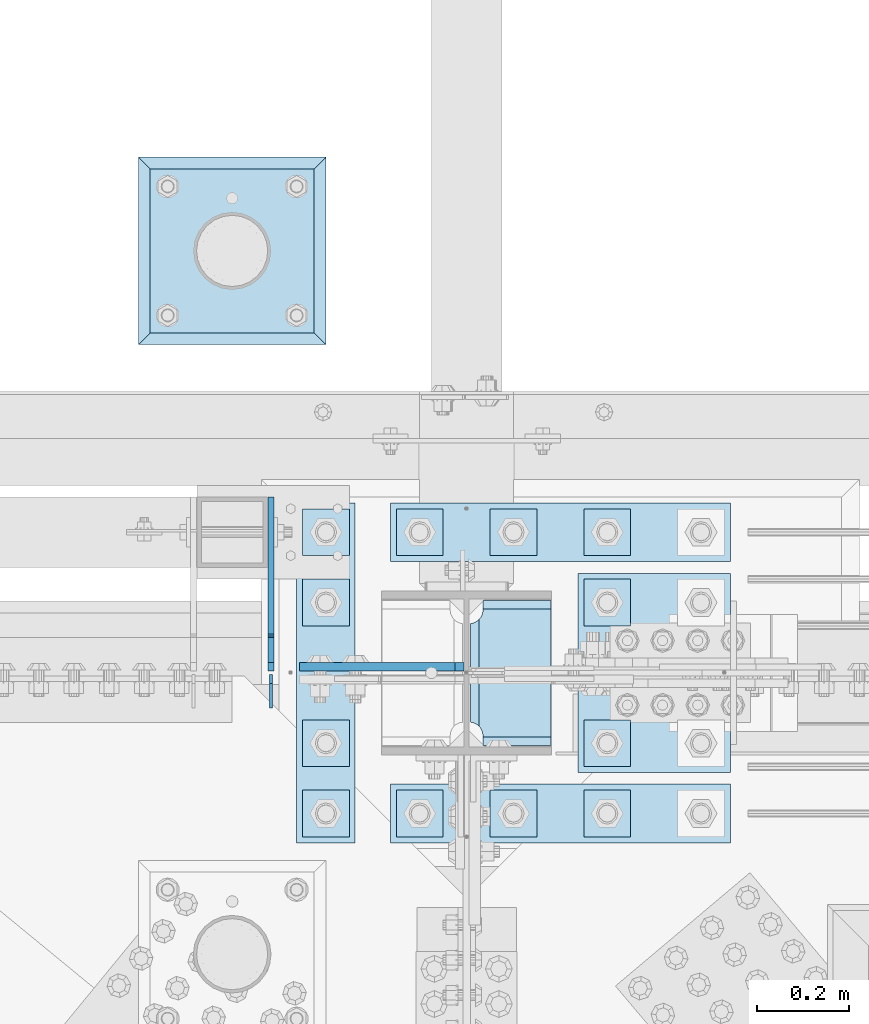
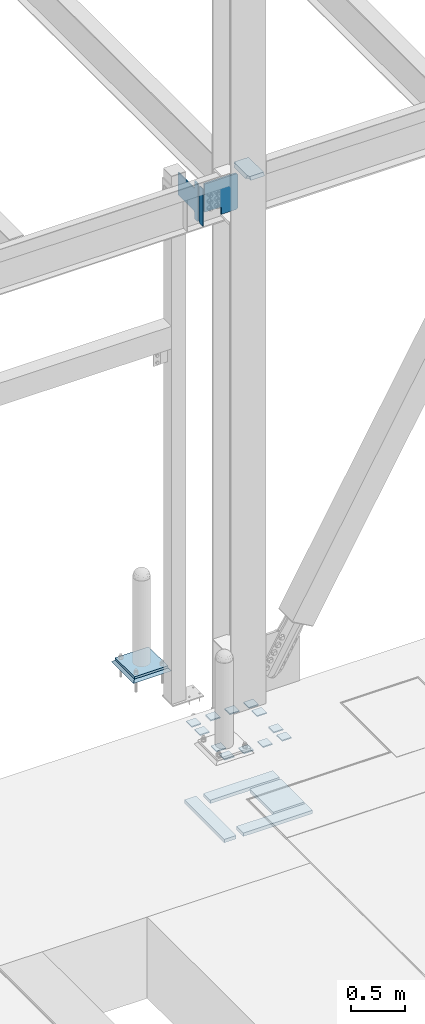
# One storey, part 3463 of 3843: 22 plates, 5 elements without a shape of their own.
"""IFC2X3 building model written with IfcOpenShell, lengths in millimetres."""

from ifc_helpers import new_model, si_unit, frame, origin_with_axes, place, context, subcontext, project, spatial, faceted_brep, material, type_object, element, aggregate, save


model = new_model("IFC2X3")

# Units and contexts
model_context = context("Model", 3, precision=1e-05, world=origin_with_axes())
body_context = subcontext(model_context, "Body", "Model", "MODEL_VIEW")
ifc_project = project(units=[si_unit("LENGTHUNIT", "METRE", prefix="MILLI"), si_unit("AREAUNIT", "SQUARE_METRE"), si_unit("VOLUMEUNIT", "CUBIC_METRE"), si_unit("MASSUNIT", "GRAM", prefix="KILO"), si_unit("TIMEUNIT", "SECOND"), si_unit("PLANEANGLEUNIT", "RADIAN"), si_unit("SOLIDANGLEUNIT", "STERADIAN"), si_unit("THERMODYNAMICTEMPERATUREUNIT", "DEGREE_CELSIUS"), si_unit("LUMINOUSINTENSITYUNIT", "LUMEN")], contexts=[model_context])

# Site, building, storey
site_placement = place(None, origin_with_axes())
site = spatial("IfcSite", under=ifc_project, at=site_placement, CompositionType="ELEMENT")
building_placement = place(site_placement, origin_with_axes())
building = spatial("IfcBuilding", under=site, at=building_placement, Name="Undefined", CompositionType="ELEMENT")
storey_placement = place(building_placement, origin_with_axes())
storey = spatial("IfcBuildingStorey", under=building, at=storey_placement, Name="Undefined", CompositionType="ELEMENT", Elevation=0.0)

# Assembly, plate
assembly_1_placement = place(storey_placement, origin_with_axes())
assembly_1 = element("IfcElementAssembly", 1, at=assembly_1_placement, inside=storey, Name="PIPE_BOLLARD", AssemblyPlace="NOTDEFINED", PredefinedType="RIGID_FRAME")
ifc_material_1 = material(Name="STEEL/A572-50")
plate_type_1 = type_object("IfcPlateType", PredefinedType="NOTDEFINED")
plate_1_placement = place(assembly_1_placement, frame((48310.8, 92951.3, 30518.1), z_axis=(0.0, 1.0, 0.0), x_axis=(1.0, 0.0, 0.0)))
plate_1 = element("IfcPlate", 2, at=plate_1_placement, type_object=plate_type_1, material=ifc_material_1, Name="PLATE", context=body_context, shape_type="Brep", body=[
    faceted_brep([(0.0, -12.6999999999971, 0.0), (0.0, -12.7000000000007, 355.600000000006), (0.0, 12.7000000000007, 355.600000000006), (0.0, 12.6999999999971, 0.0), (355.599999999999, -12.7000000000007, 355.600000000006), (355.599999999999, 12.7000000000007, 355.600000000006), (355.599999999999, -12.7000000000007, 0.0), (355.599999999999, 12.7000000000007, 0.0)], [[[0, 1, 2, 3]], [[1, 4, 5, 2]], [[4, 6, 7, 5]], [[6, 0, 3, 7]], [[5, 7, 3, 2]], [[6, 4, 1, 0]]]),
])
aggregate(assembly_1, [plate_1])

assembly_2_placement = place(storey_placement, origin_with_axes())
assembly_2 = element("IfcElementAssembly", 3, at=assembly_2_placement, inside=storey, Name="GROUT", AssemblyPlace="NOTDEFINED", PredefinedType="REINFORCEMENT_UNIT")
ifc_material_2 = material(Name="CONCRETE/Concrete_Undefined")
plate_type_2 = type_object("IfcPlateType", PredefinedType="NOTDEFINED")
plate_2_placement = place(assembly_2_placement, frame((48285.4, 92925.9, 30492.7), z_axis=(0.0, 1.0, 0.0), x_axis=(1.0, 0.0, 0.0)))
plate_2 = element("IfcPlate", 4, at=plate_2_placement, type_object=plate_type_2, material=ifc_material_2, Name="GROUT", context=body_context, shape_type="Brep", body=[
    faceted_brep([(25.4000000001906, -12.6999999998552, 380.999999999505), (0.0, 12.7000000000007, 406.399999999994), (0.0, 12.6999999999971, 0.0), (25.4000000001906, -12.6999999999898, 25.4000000004453), (380.999999999833, -12.6999999998588, 25.4000000004453), (406.400000000001, 12.7000000000007, 0.0), (406.400000000001, 12.7000000000007, 406.399999999994), (380.999999999833, -12.6999999999898, 380.999999999505)], [[[0, 1, 2, 3]], [[4, 5, 6, 7]], [[4, 7, 0, 3]], [[5, 4, 3, 2]], [[6, 5, 2, 1]], [[7, 6, 1, 0]]]),
])
aggregate(assembly_2, [plate_2])

assembly_3_placement = place(storey_placement, origin_with_axes())
assembly_3 = element("IfcElementAssembly", 5, at=assembly_3_placement, inside=storey, Name="COLUMN", AssemblyPlace="NOTDEFINED", PredefinedType="RIGID_FRAME")
plate_type_3 = type_object("IfcPlateType", PredefinedType="NOTDEFINED")
plate_3_placement = place(assembly_3_placement, frame((49179.95625, 92054.3625, 36420.425), z_axis=(0.0, 1.0, 0.0), x_axis=(-1.0, 0.0, 0.0)))
plate_3 = element("IfcPlate", 6, at=plate_3_placement, type_object=plate_type_3, material=ifc_material_1, Name="PLATE", context=body_context, shape_type="Brep", body=[
    faceted_brep([(160.070927103505, 9.33329077896633, 48.2144734940957), (156.294129000915, 15.875, 44.437675391513), (156.294129000915, 15.875, 276.23732460849), (160.070927103505, 9.33329077896633, 272.460526505907), (168.479274789282, -5.23062396988826, 268.176259371801), (174.625000047687, -15.875, 267.202872116366), (174.625000047687, -15.875, 53.4721278836369), (168.479274789282, -5.23062396988826, 52.4987406282016), (147.63749961853, 15.875, 21.5053709990898), (147.63749961853, -15.875, 3.17449995232164), (0.0, -15.875, 3.17449995232164), (0.0, 15.875, 21.5053709990898), (0.0, 15.875, 299.168629000924), (0.0, -15.875, 317.499500047692), (147.63749961853, -15.875, 317.499500047692), (147.63749961853, 15.875, 299.168629000924), (147.63749961853, -15.875, 296.862501907352), (147.63749961853, 15.875, 296.862501907352), (149.113757464445, -15.875, 287.541776696642), (149.113757464445, 15.875, 287.541776696642), (153.398024598548, -15.875, 279.133429010864), (153.398024598548, 15.875, 279.133429010864), (160.070927103505, -15.875, 272.460526505907), (168.479274789282, -15.875, 268.176259371801), (168.479274789282, -15.875, 52.4987406282016), (160.070927103505, -15.875, 48.2144734940957), (153.398024598548, -15.875, 41.5415709891386), (153.398024598548, 15.875, 41.5415709891386), (149.113757464449, -15.875, 33.1332233033609), (149.113757464449, 15.875, 33.1332233033609), (147.63749961853, -15.875, 23.8124980926514), (147.63749961853, 15.875, 23.8124980926514)], [[[0, 1, 2, 3, 4, 5, 6, 7]], [[8, 9, 10, 11]], [[12, 13, 14, 15]], [[13, 12, 11, 10]], [[16, 17, 15, 14]], [[16, 18, 19, 17]], [[18, 20, 21, 19]], [[21, 20, 22, 3, 2]], [[22, 23, 4, 3]], [[23, 5, 4]], [[24, 7, 6]], [[24, 25, 0, 7]], [[25, 26, 27, 1, 0]], [[26, 28, 29, 27]], [[28, 30, 31, 29]], [[31, 30, 9, 8]], [[27, 29, 31, 8, 11, 12, 15, 17, 19, 21, 2, 1]], [[9, 30, 28, 26, 25, 24, 6, 5, 23, 22, 20, 18, 16, 14, 13, 10]]]),
])

# Assembly, plates
assembly_4_placement = place(storey_placement, origin_with_axes())
assembly_4 = element("IfcElementAssembly", 7, at=assembly_4_placement, inside=storey, Name="TEMPLATE", AssemblyPlace="NOTDEFINED", PredefinedType="RIGID_FRAME")
plate_type_4 = type_object("IfcPlateType", PredefinedType="NOTDEFINED")
plate_4_placement = place(assembly_4_placement, frame((48742.6, 91960.7, 30143.45), z_axis=(-1.0, 0.0, 0.0), x_axis=(0.0, -1.0, 0.0)))
plate_4 = element("IfcPlate", 8, at=plate_4_placement, type_object=plate_type_4, material=ifc_material_1, Name="Washer Plate", context=body_context, shape_type="Brep", body=[
    faceted_brep([(0.0, -6.3499999046162, 0.0), (-1.67347025126219e-10, -6.35000000000582, 101.600000000151), (-1.67347025126219e-10, 6.35000000000582, 101.600000000151), (7.27595761418343e-12, 6.3499999046162, 0.0), (101.599998474121, -6.34999999999854, 101.599998474121), (101.599998474121, 6.34999999999854, 101.599998474121), (101.6, -6.34999999999854, 0.0), (101.6, 6.34999999999854, 0.0)], [[[0, 1, 2, 3]], [[1, 4, 5, 2]], [[4, 6, 7, 5]], [[6, 0, 3, 7]], [[5, 7, 3, 2]], [[6, 4, 1, 0]]]),
])
plate_5_placement = place(assembly_4_placement, frame((48945.8, 91960.7, 30143.45), z_axis=(-1.0, 0.0, 0.0), x_axis=(0.0, -1.0, 0.0)))
plate_5 = element("IfcPlate", 9, at=plate_5_placement, type_object=plate_type_4, material=ifc_material_1, Name="Washer Plate", context=body_context, shape_type="Brep", body=[
    faceted_brep([(0.0, -6.3499999046162, 0.0), (-1.67347025126219e-10, -6.35000000000582, 101.600000000151), (-1.67347025126219e-10, 6.35000000000582, 101.600000000151), (7.27595761418343e-12, 6.3499999046162, 0.0), (101.599998474121, -6.34999999999854, 101.599998474121), (101.599998474121, 6.34999999999854, 101.599998474121), (101.6, -6.34999999999854, 0.0), (101.6, 6.34999999999854, 0.0)], [[[0, 1, 2, 3]], [[1, 4, 5, 2]], [[4, 6, 7, 5]], [[6, 0, 3, 7]], [[5, 7, 3, 2]], [[6, 4, 1, 0]]]),
])
plate_6_placement = place(assembly_4_placement, frame((49149.0, 91960.7, 30143.45), z_axis=(-1.0, 0.0, 0.0), x_axis=(0.0, -1.0, 0.0)))
plate_6 = element("IfcPlate", 10, at=plate_6_placement, type_object=plate_type_4, material=ifc_material_1, Name="Washer Plate", context=body_context, shape_type="Brep", body=[
    faceted_brep([(0.0, -6.3499999046162, 0.0), (-1.67347025126219e-10, -6.35000000000582, 101.600000000151), (-1.67347025126219e-10, 6.35000000000582, 101.600000000151), (7.27595761418343e-12, 6.3499999046162, 0.0), (101.599998474121, -6.34999999999854, 101.599998474121), (101.599998474121, 6.34999999999854, 101.599998474121), (101.6, -6.34999999999854, 0.0), (101.6, 6.34999999999854, 0.0)], [[[0, 1, 2, 3]], [[1, 4, 5, 2]], [[4, 6, 7, 5]], [[6, 0, 3, 7]], [[5, 7, 3, 2]], [[6, 4, 1, 0]]]),
])
plate_7_placement = place(assembly_4_placement, frame((49352.2, 91960.7, 30143.45), z_axis=(-1.0, 0.0, 0.0), x_axis=(0.0, -1.0, 0.0)))
plate_7 = element("IfcPlate", 11, at=plate_7_placement, type_object=plate_type_4, material=ifc_material_1, Name="Washer Plate", context=body_context, shape_type="Brep", body=[
    faceted_brep([(0.0, -6.3499999046162, 0.0), (-1.67347025126219e-10, -6.35000000000582, 101.600000000151), (-1.67347025126219e-10, 6.35000000000582, 101.600000000151), (7.27595761418343e-12, 6.3499999046162, 0.0), (101.599998474121, -6.34999999999854, 101.599998474121), (101.599998474121, 6.34999999999854, 101.599998474121), (101.6, -6.34999999999854, 0.0), (101.6, 6.34999999999854, 0.0)], [[[0, 1, 2, 3]], [[1, 4, 5, 2]], [[4, 6, 7, 5]], [[6, 0, 3, 7]], [[5, 7, 3, 2]], [[6, 4, 1, 0]]]),
])
plate_8_placement = place(assembly_4_placement, frame((48742.6, 92113.1, 30143.45), z_axis=(-1.0, 0.0, 0.0), x_axis=(0.0, -1.0, 0.0)))
plate_8 = element("IfcPlate", 12, at=plate_8_placement, type_object=plate_type_4, material=ifc_material_1, Name="Washer Plate", context=body_context, shape_type="Brep", body=[
    faceted_brep([(0.0, -6.3499999046162, 0.0), (-1.67347025126219e-10, -6.35000000000582, 101.600000000151), (-1.67347025126219e-10, 6.35000000000582, 101.600000000151), (7.27595761418343e-12, 6.3499999046162, 0.0), (101.599998474121, -6.34999999999854, 101.599998474121), (101.599998474121, 6.34999999999854, 101.599998474121), (101.6, -6.34999999999854, 0.0), (101.6, 6.34999999999854, 0.0)], [[[0, 1, 2, 3]], [[1, 4, 5, 2]], [[4, 6, 7, 5]], [[6, 0, 3, 7]], [[5, 7, 3, 2]], [[6, 4, 1, 0]]]),
])
plate_9_placement = place(assembly_4_placement, frame((49352.2, 92113.1, 30143.45), z_axis=(-1.0, 0.0, 0.0), x_axis=(0.0, -1.0, 0.0)))
plate_9 = element("IfcPlate", 13, at=plate_9_placement, type_object=plate_type_4, material=ifc_material_1, Name="Washer Plate", context=body_context, shape_type="Brep", body=[
    faceted_brep([(0.0, -6.3499999046162, 0.0), (-1.67347025126219e-10, -6.35000000000582, 101.600000000151), (-1.67347025126219e-10, 6.35000000000582, 101.600000000151), (7.27595761418343e-12, 6.3499999046162, 0.0), (101.599998474121, -6.34999999999854, 101.599998474121), (101.599998474121, 6.34999999999854, 101.599998474121), (101.6, -6.34999999999854, 0.0), (101.6, 6.34999999999854, 0.0)], [[[0, 1, 2, 3]], [[1, 4, 5, 2]], [[4, 6, 7, 5]], [[6, 0, 3, 7]], [[5, 7, 3, 2]], [[6, 4, 1, 0]]]),
])
plate_10_placement = place(assembly_4_placement, frame((48742.6, 92417.9, 30143.45), z_axis=(-1.0, 0.0, 0.0), x_axis=(0.0, -1.0, 0.0)))
plate_10 = element("IfcPlate", 14, at=plate_10_placement, type_object=plate_type_4, material=ifc_material_1, Name="Washer Plate", context=body_context, shape_type="Brep", body=[
    faceted_brep([(0.0, -6.3499999046162, 0.0), (-1.67347025126219e-10, -6.35000000000582, 101.600000000151), (-1.67347025126219e-10, 6.35000000000582, 101.600000000151), (7.27595761418343e-12, 6.3499999046162, 0.0), (101.599998474121, -6.34999999999854, 101.599998474121), (101.599998474121, 6.34999999999854, 101.599998474121), (101.6, -6.34999999999854, 0.0), (101.6, 6.34999999999854, 0.0)], [[[0, 1, 2, 3]], [[1, 4, 5, 2]], [[4, 6, 7, 5]], [[6, 0, 3, 7]], [[5, 7, 3, 2]], [[6, 4, 1, 0]]]),
])
plate_11_placement = place(assembly_4_placement, frame((49352.2, 92417.9, 30143.45), z_axis=(-1.0, 0.0, 0.0), x_axis=(0.0, -1.0, 0.0)))
plate_11 = element("IfcPlate", 15, at=plate_11_placement, type_object=plate_type_4, material=ifc_material_1, Name="Washer Plate", context=body_context, shape_type="Brep", body=[
    faceted_brep([(0.0, -6.3499999046162, 0.0), (-1.67347025126219e-10, -6.35000000000582, 101.600000000151), (-1.67347025126219e-10, 6.35000000000582, 101.600000000151), (7.27595761418343e-12, 6.3499999046162, 0.0), (101.599998474121, -6.34999999999854, 101.599998474121), (101.599998474121, 6.34999999999854, 101.599998474121), (101.6, -6.34999999999854, 0.0), (101.6, 6.34999999999854, 0.0)], [[[0, 1, 2, 3]], [[1, 4, 5, 2]], [[4, 6, 7, 5]], [[6, 0, 3, 7]], [[5, 7, 3, 2]], [[6, 4, 1, 0]]]),
])
plate_12_placement = place(assembly_4_placement, frame((48742.6, 92570.3, 30143.45), z_axis=(-1.0, 0.0, 0.0), x_axis=(0.0, -1.0, 0.0)))
plate_12 = element("IfcPlate", 16, at=plate_12_placement, type_object=plate_type_4, material=ifc_material_1, Name="Washer Plate", context=body_context, shape_type="Brep", body=[
    faceted_brep([(0.0, -6.3499999046162, 0.0), (-1.67347025126219e-10, -6.35000000000582, 101.600000000151), (-1.67347025126219e-10, 6.35000000000582, 101.600000000151), (7.27595761418343e-12, 6.3499999046162, 0.0), (101.599998474121, -6.34999999999854, 101.599998474121), (101.599998474121, 6.34999999999854, 101.599998474121), (101.6, -6.34999999999854, 0.0), (101.6, 6.34999999999854, 0.0)], [[[0, 1, 2, 3]], [[1, 4, 5, 2]], [[4, 6, 7, 5]], [[6, 0, 3, 7]], [[5, 7, 3, 2]], [[6, 4, 1, 0]]]),
])
plate_13_placement = place(assembly_4_placement, frame((48945.8, 92570.3, 30143.45), z_axis=(-1.0, 0.0, 0.0), x_axis=(0.0, -1.0, 0.0)))
plate_13 = element("IfcPlate", 17, at=plate_13_placement, type_object=plate_type_4, material=ifc_material_1, Name="Washer Plate", context=body_context, shape_type="Brep", body=[
    faceted_brep([(0.0, -6.3499999046162, 0.0), (-1.67347025126219e-10, -6.35000000000582, 101.600000000151), (-1.67347025126219e-10, 6.35000000000582, 101.600000000151), (7.27595761418343e-12, 6.3499999046162, 0.0), (101.599998474121, -6.34999999999854, 101.599998474121), (101.599998474121, 6.34999999999854, 101.599998474121), (101.6, -6.34999999999854, 0.0), (101.6, 6.34999999999854, 0.0)], [[[0, 1, 2, 3]], [[1, 4, 5, 2]], [[4, 6, 7, 5]], [[6, 0, 3, 7]], [[5, 7, 3, 2]], [[6, 4, 1, 0]]]),
])
plate_14_placement = place(assembly_4_placement, frame((49149.0, 92570.3, 30143.45), z_axis=(-1.0, 0.0, 0.0), x_axis=(0.0, -1.0, 0.0)))
plate_14 = element("IfcPlate", 18, at=plate_14_placement, type_object=plate_type_4, material=ifc_material_1, Name="Washer Plate", context=body_context, shape_type="Brep", body=[
    faceted_brep([(0.0, -6.3499999046162, 0.0), (-1.67347025126219e-10, -6.35000000000582, 101.600000000151), (-1.67347025126219e-10, 6.35000000000582, 101.600000000151), (7.27595761418343e-12, 6.3499999046162, 0.0), (101.599998474121, -6.34999999999854, 101.599998474121), (101.599998474121, 6.34999999999854, 101.599998474121), (101.6, -6.34999999999854, 0.0), (101.6, 6.34999999999854, 0.0)], [[[0, 1, 2, 3]], [[1, 4, 5, 2]], [[4, 6, 7, 5]], [[6, 0, 3, 7]], [[5, 7, 3, 2]], [[6, 4, 1, 0]]]),
])
plate_15_placement = place(assembly_4_placement, frame((49352.2, 92570.3, 30143.45), z_axis=(-1.0, 0.0, 0.0), x_axis=(0.0, -1.0, 0.0)))
plate_15 = element("IfcPlate", 19, at=plate_15_placement, type_object=plate_type_4, material=ifc_material_1, Name="Washer Plate", context=body_context, shape_type="Brep", body=[
    faceted_brep([(0.0, -6.3499999046162, 0.0), (-1.67347025126219e-10, -6.35000000000582, 101.600000000151), (-1.67347025126219e-10, 6.35000000000582, 101.600000000151), (7.27595761418343e-12, 6.3499999046162, 0.0), (101.599998474121, -6.34999999999854, 101.599998474121), (101.599998474121, 6.34999999999854, 101.599998474121), (101.6, -6.34999999999854, 0.0), (101.6, 6.34999999999854, 0.0)], [[[0, 1, 2, 3]], [[1, 4, 5, 2]], [[4, 6, 7, 5]], [[6, 0, 3, 7]], [[5, 7, 3, 2]], [[6, 4, 1, 0]]]),
])

# Plate
plate_type_5 = type_object("IfcPlateType", PredefinedType="NOTDEFINED")
plate_16_placement = place(assembly_3_placement, frame((48991.04375, 92228.1937503815, 36020.375), z_axis=(-0.707106781186548, 0.0, 0.707106781186548), x_axis=(-0.707106781186548, 0.0, -0.707106781186548)))
plate_16 = element("IfcPlate", 20, at=plate_16_placement, type_object=plate_type_5, material=ifc_material_1, Name="PLATE", context=body_context, shape_type="Brep", body=[
    faceted_brep([(0.0, -9.52500000000146, 0.0), (-258.182363479493, -9.52499999999418, 258.182363479486), (-258.182363479493, 9.52499999999418, 258.182363479486), (0.0, 9.52500000000146, 0.0), (-258.182363479496, -9.52499999999418, 285.123131842571), (-258.182363479496, 9.52499999999418, 285.123131842571), (-19.6443102647499, -9.52499999999418, 523.66118505731), (-19.6443102647499, 9.52499999999418, 523.66118505731), (204.862092760904, -9.52499999999418, 299.154782031677), (204.862092760904, 9.52499999999418, 299.154782031677), (88.1187630527165, -9.52499999999418, 182.411452323489), (88.1187630527165, 9.52499999999418, 182.411452323489), (85.3657491522463, -9.52499999999418, 178.291275855343), (85.3657491522463, 9.52499999999418, 178.291275855343), (84.3990192296587, -9.52499999999418, 173.431196337304), (84.3990192296587, 9.52499999999418, 173.431196337304), (85.3657491522499, -9.52499999999418, 168.571116819279), (85.3657491522499, 9.52499999999418, 168.571116819279), (88.1187630527165, -9.52499999999418, 164.450940351133), (88.1187630527165, 9.52499999999418, 164.450940351133), (139.755236456211, -9.52500000000146, 112.814466211697), (139.755236456211, 9.52500000000146, 112.814466211697), (26.9407683632344, -9.52499999999964, 2.03726813197136e-10), (26.9407683632344, 9.52499999999964, 2.03726813197136e-10)], [[[0, 1, 2, 3]], [[1, 4, 5, 2]], [[4, 6, 7, 5]], [[6, 8, 9, 7]], [[8, 10, 11, 9]], [[10, 12, 13, 11]], [[12, 14, 15, 13]], [[14, 16, 17, 15]], [[16, 18, 19, 17]], [[18, 20, 21, 19]], [[20, 22, 23, 21]], [[22, 0, 3, 23]], [[5, 7, 9, 11, 13, 15, 17, 19, 21, 23, 3, 2]], [[22, 20, 18, 16, 14, 12, 10, 8, 6, 4, 1, 0]]]),
])

aggregate(assembly_3, [plate_3, plate_16])

# Assembly, plates
assembly_5_placement = place(storey_placement, origin_with_axes())
assembly_5 = element("IfcElementAssembly", 21, at=assembly_5_placement, inside=storey, Name="BEAM", AssemblyPlace="NOTDEFINED", PredefinedType="RIGID_FRAME")
plate_type_6 = type_object("IfcPlateType", PredefinedType="NOTDEFINED")
plate_17_placement = place(assembly_5_placement, frame((48572.7375, 92138.5, 35996.5625), z_axis=(0.0, 0.0, 1.0), x_axis=(0.0, 1.0, 0.0)))
plate_17 = element("IfcPlate", 22, at=plate_17_placement, type_object=plate_type_6, material=ifc_material_1, Name="PLATE", context=body_context, shape_type="Brep", body=[
    faceted_brep([(0.0, -3.17499999999927, 0.0), (0.0, -3.17500000000291, 425.449999999997), (0.0, 3.17500000000291, 425.449999999997), (0.0, 3.17499999999927, 0.0), (53.1812477111816, -3.17500000000291, 425.450012207031), (53.1812477111816, 3.17500000000291, 425.450012207031), (72.2312469482422, -3.17500000000291, 406.400012969971), (72.2312469482422, 3.17500000000291, 406.400012969971), (72.2312469482422, -3.17500000000291, 19.0499992370605), (72.2312469482422, 3.17500000000291, 19.0499992370605), (53.1812477111816, -3.17500000000291, 0.0), (53.1812477111816, 3.17500000000291, 0.0)], [[[0, 1, 2, 3]], [[1, 4, 5, 2]], [[4, 6, 7, 5]], [[6, 8, 9, 7]], [[8, 10, 11, 9]], [[10, 0, 3, 11]], [[5, 7, 9, 11, 3, 2]], [[10, 8, 6, 4, 1, 0]]]),
])
plate_type_7 = type_object("IfcPlateType", PredefinedType="NOTDEFINED")
plate_18_placement = place(assembly_5_placement, frame((48572.7375, 92218.66875, 35996.5625), z_axis=(0.0, 0.0, 1.0), x_axis=(0.0, 1.0, 0.0)))
plate_18 = element("IfcPlate", 23, at=plate_18_placement, type_object=plate_type_7, material=ifc_material_1, Name="PLATE", context=body_context, shape_type="Brep", body=[
    faceted_brep([(0.0, -6.34999999999854, 19.0499992370605), (0.0, -6.34999999999854, 406.400000762937), (0.0, 6.34999999999854, 406.400000762937), (0.0, 6.34999999999854, 19.0499992370605), (19.0499992370605, -6.34999999999854, 425.449999999997), (19.0499992370605, 6.34999999999854, 425.449999999997), (72.2312469482422, -6.35000000000582, 425.450012207031), (72.2312469482422, 6.35000000000582, 425.450012207031), (72.2312469482422, -6.35000000000582, 350.837505912779), (72.2312469482422, 6.35000000000582, 350.837505912779), (73.1979768708261, -6.35000000000582, 345.977426394733), (73.1979768708261, 6.35000000000582, 345.977426394733), (75.9509907713073, -6.35000000000582, 341.857249926579), (75.9509907713073, 6.35000000000582, 341.857249926579), (80.0711672394682, -6.35000000000582, 339.104236026105), (80.0711672394682, 6.35000000000582, 339.104236026105), (84.9312467575073, -6.35000000000582, 338.137506103514), (84.9312467575073, 6.35000000000582, 338.137506103514), (377.03125, -6.35000000000582, 338.137506103514), (377.03125, 6.35000000000582, 338.137506103514), (377.03125, -6.35000000000582, 84.1374969482422), (377.03125, 6.35000000000582, 84.1374969482422), (84.9312467575073, -6.35000000000582, 84.1374969482422), (84.9312467575073, 6.35000000000582, 84.1374969482422), (80.0711672394682, -6.35000000000582, 83.170767025651), (80.0711672394682, 6.35000000000582, 83.170767025651), (75.9509907713073, -6.35000000000582, 80.4177531251771), (75.9509907713073, 6.35000000000582, 80.4177531251771), (73.1979768708261, -6.35000000000582, 76.2975766570235), (73.1979768708261, 6.35000000000582, 76.2975766570235), (72.2312469482422, -6.35000000000582, 71.4374971389771), (72.2312469482422, 6.35000000000582, 71.4374971389771), (72.2312469482422, -6.35000000000582, 0.0), (72.2312469482422, 6.35000000000582, 0.0), (19.0499992370605, -6.34999999999854, 0.0), (19.0499992370605, 6.34999999999854, 0.0)], [[[0, 1, 2, 3]], [[1, 4, 5, 2]], [[4, 6, 7, 5]], [[6, 8, 9, 7]], [[8, 10, 11, 9]], [[10, 12, 13, 11]], [[12, 14, 15, 13]], [[14, 16, 17, 15]], [[16, 18, 19, 17]], [[18, 20, 21, 19]], [[20, 22, 23, 21]], [[22, 24, 25, 23]], [[24, 26, 27, 25]], [[26, 28, 29, 27]], [[28, 30, 31, 29]], [[30, 32, 33, 31]], [[32, 34, 35, 33]], [[34, 0, 3, 35]], [[5, 7, 9, 11, 13, 15, 17, 19, 21, 23, 25, 27, 29, 31, 33, 35, 3, 2]], [[34, 32, 30, 28, 26, 24, 22, 20, 18, 16, 14, 12, 10, 8, 6, 4, 1, 0]]]),
])
aggregate(assembly_5, [plate_17, plate_18])

# Plate
plate_type_8 = type_object("IfcPlateType", PredefinedType="NOTDEFINED")
plate_19_placement = place(assembly_4_placement, frame((48628.3, 92583.0, 29241.75), z_axis=(1.0, 0.0, 0.0), x_axis=(0.0, -1.0, 0.0)))
plate_19 = element("IfcPlate", 24, at=plate_19_placement, type_object=plate_type_8, material=ifc_material_1, Name="PLATE", context=body_context, shape_type="Brep", body=[
    faceted_brep([(0.0, -19.0500000000029, 0.0), (0.0, -19.0499999999993, 127.0), (0.0, 19.0499999999993, 127.0), (0.0, 19.0500000000029, 0.0), (736.599975585938, -19.0499999999993, 127.0), (736.599975585938, 19.0499999999993, 127.0), (736.599975585938, -19.0499999999993, 0.0), (736.599975585938, 19.0499999999993, 0.0)], [[[0, 1, 2, 3]], [[1, 4, 5, 2]], [[4, 6, 7, 5]], [[6, 0, 3, 7]], [[5, 7, 3, 2]], [[6, 4, 1, 0]]]),
])

plate_20_placement = place(assembly_4_placement, frame((48831.5, 92583.0, 29241.75), z_axis=(1.0, 0.0, 0.0), x_axis=(0.0, -1.0, 0.0)))
plate_20 = element("IfcPlate", 25, at=plate_20_placement, type_object=plate_type_8, material=ifc_material_1, Name="PLATE", context=body_context, shape_type="Brep", body=[
    faceted_brep([(0.0, -19.0500000000029, 0.0), (0.0, -19.0499999999993, 736.600036621094), (0.0, 19.0499999999993, 736.600036621094), (0.0, 19.0500000000029, 0.0), (127.0, -19.0499999999993, 736.600036621094), (127.0, 19.0499999999993, 736.600036621094), (127.0, -19.0499999999993, 0.0), (127.0, 19.0499999999993, 0.0)], [[[0, 1, 2, 3]], [[1, 4, 5, 2]], [[4, 6, 7, 5]], [[6, 0, 3, 7]], [[5, 7, 3, 2]], [[6, 4, 1, 0]]]),
])

plate_21_placement = place(assembly_4_placement, frame((48831.5, 91973.4, 29241.75), z_axis=(1.0, 0.0, 0.0), x_axis=(0.0, -1.0, 0.0)))
plate_21 = element("IfcPlate", 26, at=plate_21_placement, type_object=plate_type_8, material=ifc_material_1, Name="PLATE", context=body_context, shape_type="Brep", body=[
    faceted_brep([(0.0, -19.0500000000029, 0.0), (0.0, -19.0499999999993, 736.600036621094), (0.0, 19.0499999999993, 736.600036621094), (0.0, 19.0500000000029, 0.0), (127.0, -19.0499999999993, 736.600036621094), (127.0, 19.0499999999993, 736.600036621094), (127.0, -19.0499999999993, 0.0), (127.0, 19.0499999999993, 0.0)], [[[0, 1, 2, 3]], [[1, 4, 5, 2]], [[4, 6, 7, 5]], [[6, 0, 3, 7]], [[5, 7, 3, 2]], [[6, 4, 1, 0]]]),
])

plate_type_9 = type_object("IfcPlateType", PredefinedType="NOTDEFINED")
plate_22_placement = place(assembly_4_placement, frame((49237.9, 92430.6, 29241.75), z_axis=(1.0, 0.0, 0.0), x_axis=(0.0, -1.0, 0.0)))
plate_22 = element("IfcPlate", 27, at=plate_22_placement, type_object=plate_type_9, material=ifc_material_1, Name="PLATE", context=body_context, shape_type="Brep", body=[
    faceted_brep([(0.0, -19.0500000000029, 0.0), (0.0, -19.0499999999993, 330.200012207031), (0.0, 19.0499999999993, 330.200012207031), (0.0, 19.0500000000029, 0.0), (431.799957275391, -19.0499999999993, 330.200012207031), (431.799957275391, 19.0499999999993, 330.200012207031), (431.799957275391, -19.0499999999993, 0.0), (431.799957275391, 19.0499999999993, 0.0)], [[[0, 1, 2, 3]], [[1, 4, 5, 2]], [[4, 6, 7, 5]], [[6, 0, 3, 7]], [[5, 7, 3, 2]], [[6, 4, 1, 0]]]),
])

aggregate(assembly_4, [plate_19, plate_22, plate_20, plate_21, plate_4, plate_5, plate_6, plate_7, plate_8, plate_9, plate_10, plate_11, plate_12, plate_13, plate_14, plate_15])

save(model, "model.ifc")
